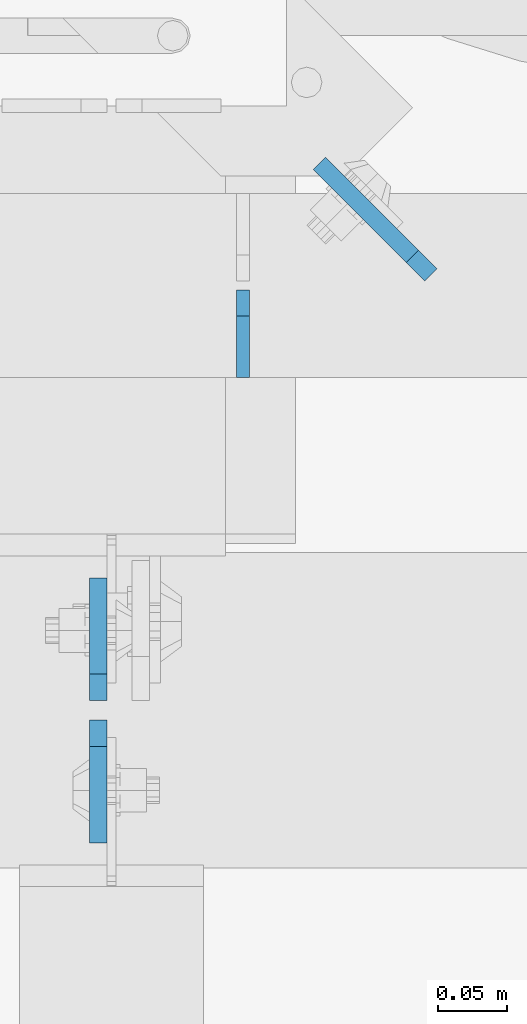
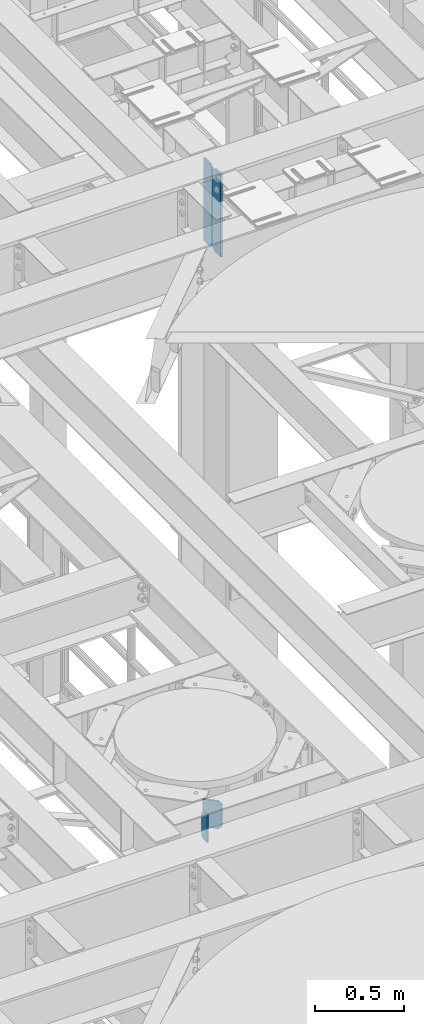
# One storey, part 1577 of 1876: 4 plates, 2 elements without a shape of their own.
"""IFC2X3 building model written with IfcOpenShell, lengths in millimetres."""

import ifcopenshell
import ifcopenshell.guid

model = None  # the IFC model being written
_history = None  # IfcOwnerHistory: only IFC2X3 demands one
_inside = {}  # id of a spatial element -> (the spatial element, [elements in it])
_under = {}  # id of a project, library or spatial element -> (it, [spatial elements below it])
_declared = {}  # id of a project -> (the project, [libraries it declares])
_typed = {}  # id of a type object -> (the type object, [elements of that type])
_made_of = {}  # id of a material, layer set ... -> (it, [elements and type objects made of it])


def new_model(schema):
    """Start an empty IFC model of exactly this schema.

    Asked for "IFC4X3", IfcOpenShell would pick the latest addendum, in which some entities
    have other attributes; the version numbers below select the first issue.
    IFC2X3 requires an IfcOwnerHistory on every rooted entity: one is made here for all.
    """
    global model, _history
    if schema == "IFC4X3":
        model = ifcopenshell.file(schema_version=(4, 3, 0, 0))
    else:
        model = ifcopenshell.file(schema=schema)
    _inside.clear()
    _under.clear()
    _declared.clear()
    _typed.clear()
    _made_of.clear()
    _history = None
    if model.schema == "IFC2X3":
        org = make("IfcOrganization", Name="unknown")
        user = make(
            "IfcPersonAndOrganization",
            ThePerson=make("IfcPerson", FamilyName="unknown"),
            TheOrganization=org,
        )
        app = make(
            "IfcApplication",
            ApplicationDeveloper=org,
            Version="unknown",
            ApplicationFullName="unknown",
            ApplicationIdentifier="unknown",
        )
        _history = make(
            "IfcOwnerHistory",
            OwningUser=user,
            OwningApplication=app,
            ChangeAction="ADDED",
            CreationDate=0,
        )
    return model


def make(cls, **values):
    """One entity of the class cls with the attributes given. An attribute that is None is left unset."""
    return model.create_entity(
        cls, **{name: value for name, value in values.items() if value is not None}
    )


def rooted(cls, **values):
    """An entity with a GlobalId (a new one), such as an element, a storey or a relation."""
    return make(cls, GlobalId=ifcopenshell.guid.new(), OwnerHistory=_history, **values)


def si_unit(unit_type, name, prefix=None):
    """IfcSIUnit, for example si_unit("LENGTHUNIT", "METRE", prefix="MILLI")."""
    return make("IfcSIUnit", UnitType=unit_type, Prefix=prefix, Name=name)


def assignment(units):
    """IfcUnitAssignment: the units of a project."""
    return None if units is None else make("IfcUnitAssignment", Units=units)


def point(xyz):
    """IfcCartesianPoint."""
    return None if xyz is None else make("IfcCartesianPoint", Coordinates=xyz)


def direction(xyz):
    """IfcDirection."""
    return None if xyz is None else make("IfcDirection", DirectionRatios=xyz)


def frame(location, z_axis=None, x_axis=None):
    """IfcAxis2Placement3D, a coordinate frame: its origin and axes. An axis left out is left unset."""
    return make(
        "IfcAxis2Placement3D",
        Location=point(location),
        Axis=direction(z_axis),
        RefDirection=direction(x_axis),
    )


def origin_with_axes():
    """The frame at (0, 0, 0) with the z axis (0, 0, 1) and the x axis (1, 0, 0) written out."""
    return frame((0.0, 0.0, 0.0), z_axis=(0.0, 0.0, 1.0), x_axis=(1.0, 0.0, 0.0))


def place(relative_to, where):
    """IfcLocalPlacement: puts the frame where relative to a parent placement (None: the world)."""
    return make(
        "IfcLocalPlacement", PlacementRelTo=relative_to, RelativePlacement=where
    )


def context(
    kind, dimensions, precision=None, world=None, true_north=None, identifier=None
):
    """IfcGeometricRepresentationContext, for example the 3D "Model" context."""
    return make(
        "IfcGeometricRepresentationContext",
        ContextIdentifier=identifier,
        ContextType=kind,
        CoordinateSpaceDimension=dimensions,
        Precision=precision,
        WorldCoordinateSystem=world,
        TrueNorth=true_north,
    )


def subcontext(parent, identifier, kind, view, scale=None):
    """IfcGeometricRepresentationSubContext, for example "Body" below "Model"."""
    return make(
        "IfcGeometricRepresentationSubContext",
        ContextIdentifier=identifier,
        ContextType=kind,
        ParentContext=parent,
        TargetScale=scale,
        TargetView=view,
    )


def project(units=None, contexts=None):
    """IfcProject with its units and contexts."""
    return rooted(
        "IfcProject",
        Name="project",
        RepresentationContexts=contexts,
        UnitsInContext=assignment(units),
    )


def spatial(cls, under=None, at=None, **own):
    """A site, building, storey or space (cls), placed at a placement, below another one or the project."""
    s = rooted(cls, ObjectPlacement=at, **own)
    if under is not None:
        _under.setdefault(under.id(), (under, []))[1].append(s)
    return s


def faces_of(points, faces, orient=None, outer=None):
    """IfcFace entities. A face is a list of loops; a loop is a list of indices into points, from 0.

    orient and outer hold one flag for each loop. By default every Orientation is true, the
    first loop of a face is its IfcFaceOuterBound and the others are IfcFaceBound.
    """
    made = []
    for i, loops in enumerate(faces):
        bounds = []
        for j, loop in enumerate(loops):
            is_outer = j == 0 if outer is None else outer[i][j]
            bounds.append(
                make(
                    "IfcFaceOuterBound" if is_outer else "IfcFaceBound",
                    Bound=make("IfcPolyLoop", Polygon=[points[k] for k in loop]),
                    Orientation=True if orient is None else orient[i][j],
                )
            )
        made.append(make("IfcFace", Bounds=bounds))
    return made


def faceted_brep(points, faces, orient=None, outer=None, voids=None):
    """IfcFacetedBrep: a solid bounded by flat faces; with voids (closed shells), ...WithVoids."""
    shared = [point(p) for p in points]
    hull = make("IfcClosedShell", CfsFaces=faces_of(shared, faces, orient, outer))
    if voids is None:
        return make("IfcFacetedBrep", Outer=hull)
    return make(
        "IfcFacetedBrepWithVoids",
        Outer=hull,
        Voids=[
            make(cls, CfsFaces=faces_of(shared, fs, o, b)) for cls, fs, o, b in voids
        ],
    )


def shape(context_of_items, identifier, shape_type, items):
    """IfcShapeRepresentation: the items that make up one representation, for example the "Body"."""
    return make(
        "IfcShapeRepresentation",
        ContextOfItems=context_of_items,
        RepresentationIdentifier=identifier,
        RepresentationType=shape_type,
        Items=items,
    )


def material(Name=None, Category=None):
    """IfcMaterial."""
    return make("IfcMaterial", Name=Name, Category=Category)


def made_of(thing, what):
    """Note that an element or type object is made of a material, layer set ...; save() writes the relation."""
    if what is not None:
        _made_of.setdefault(what.id(), (what, []))[1].append(thing)
    return thing


def type_object(cls, material=None, **own):
    """A type object (cls), such as IfcWallType, which elements share."""
    return made_of(rooted(cls, **own), material)


def element(
    cls,
    number,
    at=None,
    inside=None,
    cuts=None,
    type_object=None,
    material=None,
    context=None,
    identifier="Body",
    shape_type=None,
    held_by="IfcProductDefinitionShape",
    body=None,
    shapes=None,
    **own,
):
    """One element of the class cls, such as IfcWall. Its Tag is "e" and its number.

    at: its placement. inside: the storey or other place that contains it. cuts: it is an
    opening in that element (IfcRelVoidsElement). A single representation is given by context,
    identifier, shape_type and body (its items); several are given by shapes. held_by: the class
    of the entity that holds the representations. save() writes the other relations.
    """
    e = rooted(cls, Tag="e%d" % number, ObjectPlacement=at, **own)
    if body is not None:
        shapes = [shape(context, identifier, shape_type, body)]
    if shapes is not None:
        e.Representation = make(held_by, Representations=shapes)
    if inside is not None:
        _inside.setdefault(inside.id(), (inside, []))[1].append(e)
    if cuts is not None:
        rooted(
            "IfcRelVoidsElement", RelatingBuildingElement=cuts, RelatedOpeningElement=e
        )
    if type_object is not None:
        _typed.setdefault(type_object.id(), (type_object, []))[1].append(e)
    return made_of(e, material)


def aggregate(whole, parts):
    """IfcRelAggregates: a whole, such as a stair, and the parts it consists of."""
    return rooted("IfcRelAggregates", RelatingObject=whole, RelatedObjects=parts)


def save(model, path):
    """Write the relations noted so far, then the file.

    IfcRelAggregates (storeys below a building ...), IfcRelContainedInSpatialStructure (elements
    in a storey), IfcRelDefinesByType, IfcRelAssociatesMaterial and IfcRelDeclares: one each for
    every whole, place, type object, material and project.
    """
    for whole, parts in _under.values():
        aggregate(whole, parts)
    for where, things in _inside.values():
        rooted(
            "IfcRelContainedInSpatialStructure",
            RelatedElements=things,
            RelatingStructure=where,
        )
    for kind, things in _typed.values():
        rooted("IfcRelDefinesByType", RelatedObjects=things, RelatingType=kind)
    for what, things in _made_of.values():
        rooted("IfcRelAssociatesMaterial", RelatedObjects=things, RelatingMaterial=what)
    for by, libraries in _declared.values():
        rooted("IfcRelDeclares", RelatingContext=by, RelatedDefinitions=libraries)
    model.write(path)


model = new_model("IFC2X3")

# Units and contexts
model_context = context("Model", 3, precision=1e-05, world=origin_with_axes())
body_context = subcontext(model_context, "Body", "Model", "MODEL_VIEW")
ifc_project = project(units=[si_unit("LENGTHUNIT", "METRE", prefix="MILLI"), si_unit("AREAUNIT", "SQUARE_METRE"), si_unit("VOLUMEUNIT", "CUBIC_METRE"), si_unit("MASSUNIT", "GRAM", prefix="KILO"), si_unit("TIMEUNIT", "SECOND"), si_unit("PLANEANGLEUNIT", "RADIAN"), si_unit("SOLIDANGLEUNIT", "STERADIAN"), si_unit("THERMODYNAMICTEMPERATUREUNIT", "DEGREE_CELSIUS"), si_unit("LUMINOUSINTENSITYUNIT", "LUMEN")], contexts=[model_context])

# Site, building, storey
site_placement = place(None, origin_with_axes())
site = spatial("IfcSite", under=ifc_project, at=site_placement, CompositionType="ELEMENT")
building_placement = place(site_placement, origin_with_axes())
building = spatial("IfcBuilding", under=site, at=building_placement, Name="Undefined", CompositionType="ELEMENT")
storey_placement = place(building_placement, origin_with_axes())
storey = spatial("IfcBuildingStorey", under=building, at=storey_placement, Name="Undefined", CompositionType="ELEMENT", Elevation=0.0)

# Assembly, plate
assembly_1_placement = place(storey_placement, origin_with_axes())
assembly_1 = element("IfcElementAssembly", 1, at=assembly_1_placement, inside=storey, Name="BEAM", AssemblyPlace="NOTDEFINED", PredefinedType="RIGID_FRAME")
ifc_material = material(Name="STEEL/A36")
plate_type_1 = type_object("IfcPlateType", PredefinedType="NOTDEFINED")
plate_1_placement = place(assembly_1_placement, frame((4108.45, 1765.3, 13111.1625), z_axis=(0.0, 0.0, 1.0), x_axis=(0.0, 1.0, 0.0)))
plate_1 = element("IfcPlate", 2, at=plate_1_placement, type_object=plate_type_1, material=ifc_material, Name="PLATE", context=body_context, shape_type="Brep", body=[
    faceted_brep([(0.0, -4.76249999999982, 0.0), (0.0, -4.76249999999982, 190.5), (0.0, 4.76249999999982, 190.5), (0.0, 4.76249999999982, 0.0), (44.4500007629395, -4.76249999999982, 190.5), (44.4500007629395, 4.76249999999982, 190.5), (63.5, -4.76249999999982, 171.450000762939), (63.5, 4.76249999999982, 171.450000762939), (63.5, -4.76249999999982, 19.0499992370605), (63.5, 4.76249999999982, 19.0499992370605), (44.4500007629395, -4.76249999999982, 0.0), (44.4500007629395, 4.76249999999982, 0.0)], [[[0, 1, 2, 3]], [[1, 4, 5, 2]], [[4, 6, 7, 5]], [[6, 8, 9, 7]], [[8, 10, 11, 9]], [[10, 0, 3, 11]], [[5, 7, 9, 11, 3, 2]], [[10, 8, 6, 4, 1, 0]]]),
])

# Assembly, plates
assembly_2_placement = place(storey_placement, origin_with_axes())
assembly_2 = element("IfcElementAssembly", 3, at=assembly_2_placement, inside=storey, Name="BEAM", AssemblyPlace="NOTDEFINED", PredefinedType="RIGID_FRAME")
plate_type_2 = type_object("IfcPlateType", PredefinedType="NOTDEFINED")
plate_2_placement = place(assembly_2_placement, frame((4003.67517775661, 1531.14375, 17387.8875), z_axis=(0.0, 0.0, 1.0), x_axis=(0.0, 1.0, 0.0)))
plate_2 = element("IfcPlate", 4, at=plate_2_placement, type_object=plate_type_2, material=ifc_material, Name="PLATE", context=body_context, shape_type="Brep", body=[
    faceted_brep([(0.0, -6.35000000000196, 19.0499992370605), (0.0, -6.34999999999991, 550.862476348877), (0.0, 6.34999999999991, 550.862476348877), (0.0, 6.35000000000105, 19.0499992370605), (19.0499992370605, -6.34999999999991, 569.912475585938), (19.0499992370605, 6.34999999999991, 569.912475585938), (88.9000015258616, -6.35000000001173, 569.912475585938), (88.9000015258634, 6.34999999998627, 569.912475585938), (88.9000015258789, -6.34999999999991, 0.0), (88.9000015258789, 6.34999999999991, 0.0), (19.0499992370642, -6.35000000000105, 0.0), (19.0499992370633, 6.35000000000105, 0.0)], [[[0, 1, 2, 3]], [[1, 4, 5, 2]], [[4, 6, 7, 5]], [[6, 8, 9, 7]], [[8, 10, 11, 9]], [[10, 0, 3, 11]], [[5, 7, 9, 11, 3, 2]], [[10, 8, 6, 4, 1, 0]]]),
])
plate_3_placement = place(assembly_2_placement, frame((4003.67517775661, 1516.85625, 17387.8875), z_axis=(0.0, 0.0, 1.0), x_axis=(0.0, -1.0, 0.0)))
plate_3 = element("IfcPlate", 5, at=plate_3_placement, type_object=plate_type_2, material=ifc_material, Name="PLATE", context=body_context, shape_type="Brep", body=[
    faceted_brep([(0.0, -6.35000000000196, 19.0499992370605), (0.0, -6.34999999999991, 550.862476348877), (0.0, 6.34999999999991, 550.862476348877), (0.0, 6.35000000000105, 19.0499992370605), (19.0499992370605, -6.34999999999991, 569.912475585938), (19.0499992370605, 6.34999999999991, 569.912475585938), (88.9000015258616, -6.35000000001173, 569.912475585938), (88.9000015258634, 6.34999999998627, 569.912475585938), (88.9000015258789, -6.34999999999991, 0.0), (88.9000015258789, 6.34999999999991, 0.0), (19.0499992370642, -6.35000000000105, 0.0), (19.0499992370633, 6.35000000000105, 0.0)], [[[0, 1, 2, 3]], [[1, 4, 5, 2]], [[4, 6, 7, 5]], [[6, 8, 9, 7]], [[8, 10, 11, 9]], [[10, 0, 3, 11]], [[5, 7, 9, 11, 3, 2]], [[10, 8, 6, 4, 1, 0]]]),
])
aggregate(assembly_2, [plate_2, plate_3])

# Plate
plate_type_3 = type_object("IfcPlateType", PredefinedType="NOTDEFINED")
plate_4_placement = place(assembly_1_placement, frame((4244.74031576117, 1839.64011096238, 13112.75), z_axis=(0.0, 0.0, 1.0), x_axis=(-0.707104099181461, 0.707109463181462, 0.0)))
plate_4 = element("IfcPlate", 6, at=plate_4_placement, type_object=plate_type_3, material=ifc_material, Name="PLATE", context=body_context, shape_type="Brep", body=[
    faceted_brep([(0.0, -6.35000000000196, 19.0499992370605), (0.0, -6.34999999999991, 169.862506866455), (0.0, 6.34999999999991, 169.862506866455), (0.0, 6.35000000000105, 19.0499992370605), (19.0499992370605, -6.34999999999991, 188.912506103516), (19.0499992370605, 6.34999999999991, 188.912506103516), (114.300003051752, -6.34999999998786, 188.912506103516), (114.300003051755, 6.35000000000741, 188.912506103516), (114.300003051752, -6.34999999998786, 0.0), (114.300003051755, 6.35000000000741, 0.0), (19.0499992370642, -6.35000000000105, 0.0), (19.0499992370633, 6.35000000000105, 0.0)], [[[0, 1, 2, 3]], [[1, 4, 5, 2]], [[4, 6, 7, 5]], [[6, 8, 9, 7]], [[8, 10, 11, 9]], [[10, 0, 3, 11]], [[5, 7, 9, 11, 3, 2]], [[10, 8, 6, 4, 1, 0]]]),
])

aggregate(assembly_1, [plate_4, plate_1])

save(model, "model.ifc")
